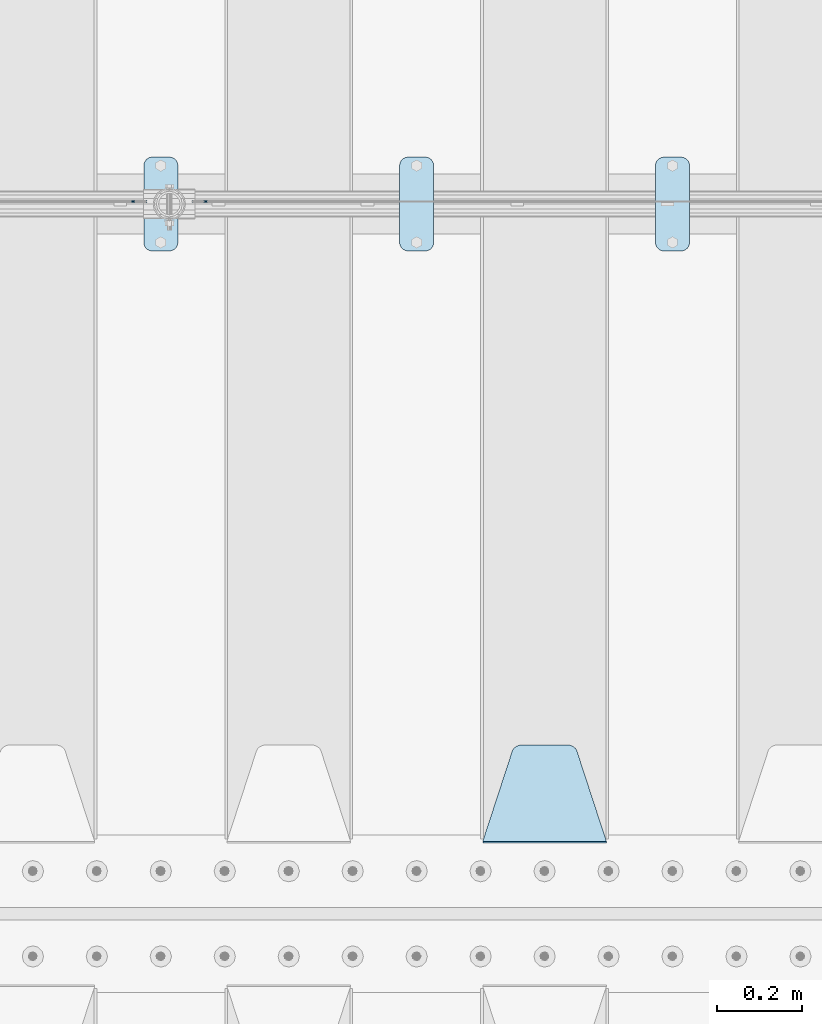
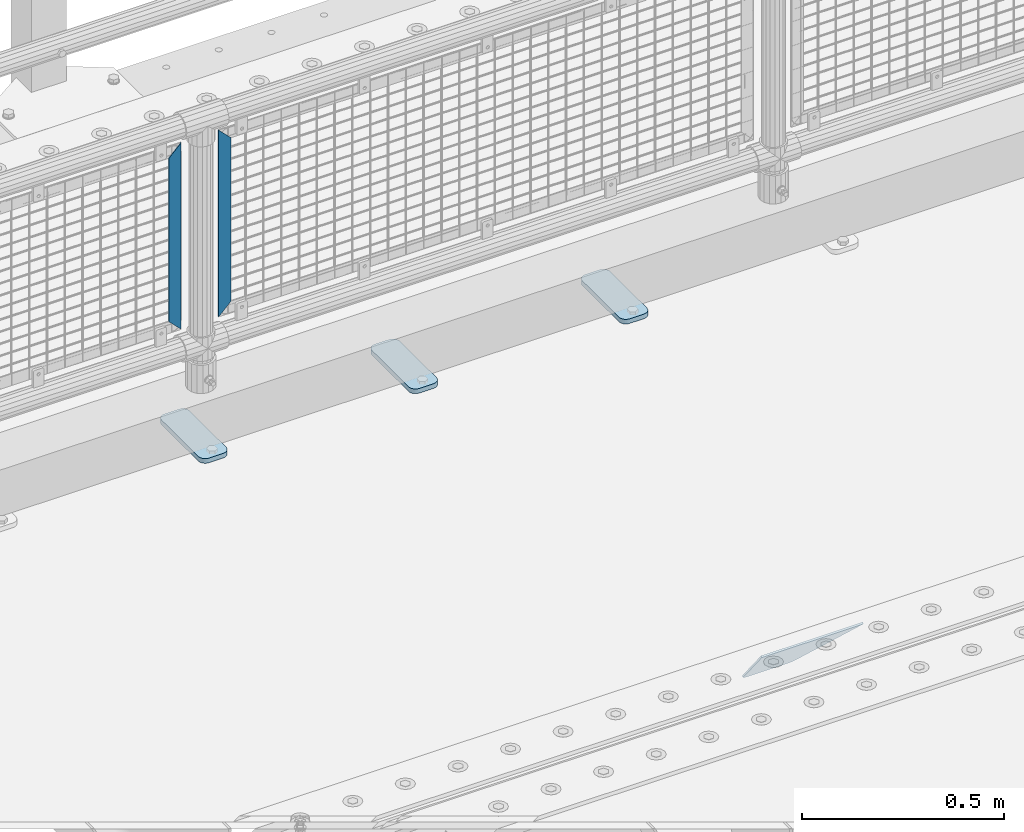
# One storey, part 203 of 242: 6 plates.
"""IFC2X3 building model written with IfcOpenShell, lengths in millimetres."""

from ifc_helpers import new_model, si_unit, frame, origin_with_axes, place, context, subcontext, project, spatial, faceted_brep, material, type_object, element, save


model = new_model("IFC2X3")

# Units and contexts
model_context = context("Model", 3, precision=1e-05, world=origin_with_axes())
body_context = subcontext(model_context, "Body", "Model", "MODEL_VIEW")
ifc_project = project(units=[si_unit("LENGTHUNIT", "METRE", prefix="MILLI"), si_unit("AREAUNIT", "SQUARE_METRE"), si_unit("VOLUMEUNIT", "CUBIC_METRE"), si_unit("MASSUNIT", "GRAM", prefix="KILO"), si_unit("TIMEUNIT", "SECOND"), si_unit("PLANEANGLEUNIT", "RADIAN"), si_unit("SOLIDANGLEUNIT", "STERADIAN"), si_unit("THERMODYNAMICTEMPERATUREUNIT", "DEGREE_CELSIUS"), si_unit("LUMINOUSINTENSITYUNIT", "LUMEN")], contexts=[model_context])

# Site, building, storey
site_placement = place(None, origin_with_axes())
site = spatial("IfcSite", under=ifc_project, at=site_placement, CompositionType="ELEMENT")
building_placement = place(site_placement, origin_with_axes())
building = spatial("IfcBuilding", under=site, at=building_placement, Name="Standard", CompositionType="ELEMENT")
storey_placement = place(building_placement, origin_with_axes())
storey = spatial("IfcBuildingStorey", under=building, at=storey_placement, Name="Undefined", CompositionType="ELEMENT", Elevation=0.0)

# Plates
ifc_material_1 = material(Name="Misc_Undefined")
plate_type_1 = type_object("IfcPlateType", PredefinedType="NOTDEFINED")
plate_1_placement = place(storey_placement, frame((-36841.490286459, -19329.5, 879.519963133601), z_axis=(-0.707008801899319, 0.0, -0.707204746899291), x_axis=(-0.707204746899296, 0.0, 0.707008801899313)))
element("IfcPlate", 1, at=plate_1_placement, inside=storey, type_object=plate_type_1, material=ifc_material_1, context=body_context, shape_type="Brep", body=[
    faceted_brep([(0.0, -1.50000000000364, 0.0), (-348.552185058597, -1.5, 348.655029296875), (-348.552185058597, 1.5, 348.655029296875), (-3.63797880709171e-12, 1.49999999999636, 0.0), (-348.544891357426, -1.5, 398.152496337891), (-348.544891357426, 1.5, 398.152496337891), (49.5043945312464, -1.5, 8.00355337560177e-11), (49.5043945312464, 1.5, 8.00355337560177e-11)], [[[0, 1, 2, 3]], [[1, 4, 5, 2]], [[4, 6, 7, 5]], [[6, 0, 3, 7]], [[5, 7, 3, 2]], [[6, 4, 1, 0]]]),
])
plate_2_placement = place(storey_placement, frame((-37018.5003125164, -19329.5, 879.52), z_axis=(0.707103624179499, 0.0, -0.707109938179501), x_axis=(0.707109938179508, 0.0, 0.707103624179492)))
element("IfcPlate", 2, at=plate_2_placement, inside=storey, type_object=plate_type_1, material=ifc_material_1, context=body_context, shape_type="Brep", body=[
    faceted_brep([(0.0, -1.50000000000364, 0.0), (-348.605163574222, -1.5, 348.602081298832), (-348.605163574222, 1.5, 348.602081298832), (-3.63797880709171e-12, 1.49999999999636, 0.0), (-348.605163574222, -1.5, 398.099334716801), (-348.605163574222, 1.5, 398.099334716801), (49.4976959228534, -1.5, -3.63797880709171e-12), (49.4976959228534, 1.5, -3.63797880709171e-12)], [[[0, 1, 2, 3]], [[1, 4, 5, 2]], [[4, 6, 7, 5]], [[6, 0, 3, 7]], [[5, 7, 3, 2]], [[6, 4, 1, 0]]]),
])
ifc_material_2 = material(Name="STEEL/S355J2")
plate_type_2 = type_object("IfcPlateType", PredefinedType="NOTDEFINED")
plate_3_placement = place(storey_placement, frame((-35790.0, -19225.5, 21.0199999999977), z_axis=(1.0, 0.0, 0.0), x_axis=(0.0, -1.0, 0.0)))
element("IfcPlate", 3, at=plate_3_placement, inside=storey, type_object=plate_type_2, material=ifc_material_2, context=body_context, shape_type="Brep", body=[
    faceted_brep([(0.0, -7.0, 20.0), (0.0, -7.0, 60.0), (0.0, 7.0, 60.0), (0.0, 7.0, 20.0), (0.384294391937146, -7.0, 63.9018064403208), (0.384294391937146, 7.0, 63.9018064403208), (1.52240934977453, -7.0, 67.6536686473009), (1.52240934977453, 7.0, 67.6536686473009), (3.37060775395003, -7.0, 71.1114046603907), (3.37060775395003, 7.0, 71.1114046603907), (5.8578643762703, -7.0, 74.1421356237297), (5.8578643762703, 7.0, 74.1421356237297), (8.88859533960931, -7.0, 76.62939224605), (8.88859533960931, 7.0, 76.62939224605), (12.3463313526991, -7.0, 78.4775906502255), (12.3463313526991, 7.0, 78.4775906502255), (16.0981935596792, -7.0, 79.6157056080629), (16.0981935596792, 7.0, 79.6157056080629), (20.0, -7.0, 80.0), (20.0, 7.0, 80.0), (200.0, -7.0, 80.0), (200.0, 7.0, 80.0), (203.901806440321, -7.0, 79.6157056080629), (203.901806440321, 7.0, 79.6157056080629), (207.653668647301, -7.0, 78.4775906502255), (207.653668647301, 7.0, 78.4775906502255), (211.111404660391, -7.0, 76.62939224605), (211.111404660391, 7.0, 76.62939224605), (214.14213562373, -7.0, 74.1421356237297), (214.14213562373, 7.0, 74.1421356237297), (216.62939224605, -7.0, 71.1114046603907), (216.62939224605, 7.0, 71.1114046603907), (218.477590650225, -7.0, 67.6536686473009), (218.477590650225, 7.0, 67.6536686473009), (219.615705608063, -7.0, 63.9018064403208), (219.615705608063, 7.0, 63.9018064403208), (220.0, -7.0, 60.0), (220.0, 7.0, 60.0), (220.0, -7.0, 20.0), (220.0, 7.0, 20.0), (219.615705608063, -7.0, 16.0981935596792), (219.615705608063, 7.0, 16.0981935596792), (218.477590650225, -7.0, 12.3463313526991), (218.477590650225, 7.0, 12.3463313526991), (216.62939224605, -7.0, 8.88859533960931), (216.62939224605, 7.0, 8.88859533960931), (214.14213562373, -7.0, 5.8578643762703), (214.14213562373, 7.0, 5.8578643762703), (211.111404660391, -7.0, 3.37060775395003), (211.111404660391, 7.0, 3.37060775395003), (207.653668647301, -7.0, 1.52240934977453), (207.653668647301, 7.0, 1.52240934977453), (203.901806440321, -7.0, 0.384294391937146), (203.901806440321, 7.0, 0.384294391937146), (200.0, -7.0, 0.0), (200.0, 7.0, 0.0), (20.0, -7.0, 0.0), (20.0, 7.0, 0.0), (16.0981935596792, -7.0, 0.384294391937146), (16.0981935596792, 7.0, 0.384294391937146), (12.3463313526991, -7.0, 1.52240934977453), (12.3463313526991, 7.0, 1.52240934977453), (8.88859533960931, -7.0, 3.37060775395003), (8.88859533960931, 7.0, 3.37060775395003), (5.8578643762703, -7.0, 5.8578643762703), (5.8578643762703, 7.0, 5.8578643762703), (3.37060775395003, -7.0, 8.88859533960931), (3.37060775395003, 7.0, 8.88859533960931), (1.52240934977453, -7.0, 12.3463313526991), (1.52240934977453, 7.0, 12.3463313526991), (0.384294391937146, -7.0, 16.0981935596792), (0.384294391937146, 7.0, 16.0981935596792)], [[[0, 1, 2, 3]], [[1, 4, 5, 2]], [[4, 6, 7, 5]], [[6, 8, 9, 7]], [[8, 10, 11, 9]], [[10, 12, 13, 11]], [[12, 14, 15, 13]], [[14, 16, 17, 15]], [[16, 18, 19, 17]], [[18, 20, 21, 19]], [[20, 22, 23, 21]], [[22, 24, 25, 23]], [[24, 26, 27, 25]], [[26, 28, 29, 27]], [[28, 30, 31, 29]], [[30, 32, 33, 31]], [[32, 34, 35, 33]], [[34, 36, 37, 35]], [[36, 38, 39, 37]], [[38, 40, 41, 39]], [[40, 42, 43, 41]], [[42, 44, 45, 43]], [[44, 46, 47, 45]], [[46, 48, 49, 47]], [[48, 50, 51, 49]], [[50, 52, 53, 51]], [[52, 54, 55, 53]], [[54, 56, 57, 55]], [[56, 58, 59, 57]], [[58, 60, 61, 59]], [[60, 62, 63, 61]], [[62, 64, 65, 63]], [[64, 66, 67, 65]], [[66, 68, 69, 67]], [[68, 70, 71, 69]], [[70, 0, 3, 71]], [[5, 7, 9, 11, 13, 15, 17, 19, 21, 23, 25, 27, 29, 31, 33, 35, 37, 39, 41, 43, 45, 47, 49, 51, 53, 55, 57, 59, 61, 63, 65, 67, 69, 71, 3, 2]], [[70, 68, 66, 64, 62, 60, 58, 56, 54, 52, 50, 48, 46, 44, 42, 40, 38, 36, 34, 32, 30, 28, 26, 24, 22, 20, 18, 16, 14, 12, 10, 8, 6, 4, 1, 0]]]),
])
plate_4_placement = place(storey_placement, frame((-36390.0, -19225.5, 21.0199999999977), z_axis=(1.0, 0.0, 0.0), x_axis=(0.0, -1.0, 0.0)))
element("IfcPlate", 4, at=plate_4_placement, inside=storey, type_object=plate_type_2, material=ifc_material_2, context=body_context, shape_type="Brep", body=[
    faceted_brep([(0.0, -7.0, 20.0), (0.0, -7.0, 60.0), (0.0, 7.0, 60.0), (0.0, 7.0, 20.0), (0.384294391937146, -7.0, 63.9018064403208), (0.384294391937146, 7.0, 63.9018064403208), (1.52240934977453, -7.0, 67.6536686473009), (1.52240934977453, 7.0, 67.6536686473009), (3.37060775395003, -7.0, 71.1114046603907), (3.37060775395003, 7.0, 71.1114046603907), (5.8578643762703, -7.0, 74.1421356237297), (5.8578643762703, 7.0, 74.1421356237297), (8.88859533960931, -7.0, 76.62939224605), (8.88859533960931, 7.0, 76.62939224605), (12.3463313526991, -7.0, 78.4775906502255), (12.3463313526991, 7.0, 78.4775906502255), (16.0981935596792, -7.0, 79.6157056080629), (16.0981935596792, 7.0, 79.6157056080629), (20.0, -7.0, 80.0), (20.0, 7.0, 80.0), (200.0, -7.0, 80.0), (200.0, 7.0, 80.0), (203.901806440321, -7.0, 79.6157056080629), (203.901806440321, 7.0, 79.6157056080629), (207.653668647301, -7.0, 78.4775906502255), (207.653668647301, 7.0, 78.4775906502255), (211.111404660391, -7.0, 76.62939224605), (211.111404660391, 7.0, 76.62939224605), (214.14213562373, -7.0, 74.1421356237297), (214.14213562373, 7.0, 74.1421356237297), (216.62939224605, -7.0, 71.1114046603907), (216.62939224605, 7.0, 71.1114046603907), (218.477590650225, -7.0, 67.6536686473009), (218.477590650225, 7.0, 67.6536686473009), (219.615705608063, -7.0, 63.9018064403208), (219.615705608063, 7.0, 63.9018064403208), (220.0, -7.0, 60.0), (220.0, 7.0, 60.0), (220.0, -7.0, 20.0), (220.0, 7.0, 20.0), (219.615705608063, -7.0, 16.0981935596792), (219.615705608063, 7.0, 16.0981935596792), (218.477590650225, -7.0, 12.3463313526991), (218.477590650225, 7.0, 12.3463313526991), (216.62939224605, -7.0, 8.88859533960931), (216.62939224605, 7.0, 8.88859533960931), (214.14213562373, -7.0, 5.8578643762703), (214.14213562373, 7.0, 5.8578643762703), (211.111404660391, -7.0, 3.37060775395003), (211.111404660391, 7.0, 3.37060775395003), (207.653668647301, -7.0, 1.52240934977453), (207.653668647301, 7.0, 1.52240934977453), (203.901806440321, -7.0, 0.384294391937146), (203.901806440321, 7.0, 0.384294391937146), (200.0, -7.0, 0.0), (200.0, 7.0, 0.0), (20.0, -7.0, 0.0), (20.0, 7.0, 0.0), (16.0981935596792, -7.0, 0.384294391937146), (16.0981935596792, 7.0, 0.384294391937146), (12.3463313526991, -7.0, 1.52240934977453), (12.3463313526991, 7.0, 1.52240934977453), (8.88859533960931, -7.0, 3.37060775395003), (8.88859533960931, 7.0, 3.37060775395003), (5.8578643762703, -7.0, 5.8578643762703), (5.8578643762703, 7.0, 5.8578643762703), (3.37060775395003, -7.0, 8.88859533960931), (3.37060775395003, 7.0, 8.88859533960931), (1.52240934977453, -7.0, 12.3463313526991), (1.52240934977453, 7.0, 12.3463313526991), (0.384294391937146, -7.0, 16.0981935596792), (0.384294391937146, 7.0, 16.0981935596792)], [[[0, 1, 2, 3]], [[1, 4, 5, 2]], [[4, 6, 7, 5]], [[6, 8, 9, 7]], [[8, 10, 11, 9]], [[10, 12, 13, 11]], [[12, 14, 15, 13]], [[14, 16, 17, 15]], [[16, 18, 19, 17]], [[18, 20, 21, 19]], [[20, 22, 23, 21]], [[22, 24, 25, 23]], [[24, 26, 27, 25]], [[26, 28, 29, 27]], [[28, 30, 31, 29]], [[30, 32, 33, 31]], [[32, 34, 35, 33]], [[34, 36, 37, 35]], [[36, 38, 39, 37]], [[38, 40, 41, 39]], [[40, 42, 43, 41]], [[42, 44, 45, 43]], [[44, 46, 47, 45]], [[46, 48, 49, 47]], [[48, 50, 51, 49]], [[50, 52, 53, 51]], [[52, 54, 55, 53]], [[54, 56, 57, 55]], [[56, 58, 59, 57]], [[58, 60, 61, 59]], [[60, 62, 63, 61]], [[62, 64, 65, 63]], [[64, 66, 67, 65]], [[66, 68, 69, 67]], [[68, 70, 71, 69]], [[70, 0, 3, 71]], [[5, 7, 9, 11, 13, 15, 17, 19, 21, 23, 25, 27, 29, 31, 33, 35, 37, 39, 41, 43, 45, 47, 49, 51, 53, 55, 57, 59, 61, 63, 65, 67, 69, 71, 3, 2]], [[70, 68, 66, 64, 62, 60, 58, 56, 54, 52, 50, 48, 46, 44, 42, 40, 38, 36, 34, 32, 30, 28, 26, 24, 22, 20, 18, 16, 14, 12, 10, 8, 6, 4, 1, 0]]]),
])
plate_5_placement = place(storey_placement, frame((-36990.0, -19225.5, 21.0199999999977), z_axis=(1.0, 0.0, 0.0), x_axis=(0.0, -1.0, 0.0)))
element("IfcPlate", 5, at=plate_5_placement, inside=storey, type_object=plate_type_2, material=ifc_material_2, context=body_context, shape_type="Brep", body=[
    faceted_brep([(0.0, -7.0, 20.0), (0.0, -7.0, 60.0), (0.0, 7.0, 60.0), (0.0, 7.0, 20.0), (0.384294391937146, -7.0, 63.9018064403208), (0.384294391937146, 7.0, 63.9018064403208), (1.52240934977453, -7.0, 67.6536686473009), (1.52240934977453, 7.0, 67.6536686473009), (3.37060775395003, -7.0, 71.1114046603907), (3.37060775395003, 7.0, 71.1114046603907), (5.8578643762703, -7.0, 74.1421356237297), (5.8578643762703, 7.0, 74.1421356237297), (8.88859533960931, -7.0, 76.62939224605), (8.88859533960931, 7.0, 76.62939224605), (12.3463313526991, -7.0, 78.4775906502255), (12.3463313526991, 7.0, 78.4775906502255), (16.0981935596792, -7.0, 79.6157056080629), (16.0981935596792, 7.0, 79.6157056080629), (20.0, -7.0, 80.0), (20.0, 7.0, 80.0), (200.0, -7.0, 80.0), (200.0, 7.0, 80.0), (203.901806440321, -7.0, 79.6157056080629), (203.901806440321, 7.0, 79.6157056080629), (207.653668647301, -7.0, 78.4775906502255), (207.653668647301, 7.0, 78.4775906502255), (211.111404660391, -7.0, 76.62939224605), (211.111404660391, 7.0, 76.62939224605), (214.14213562373, -7.0, 74.1421356237297), (214.14213562373, 7.0, 74.1421356237297), (216.62939224605, -7.0, 71.1114046603907), (216.62939224605, 7.0, 71.1114046603907), (218.477590650225, -7.0, 67.6536686473009), (218.477590650225, 7.0, 67.6536686473009), (219.615705608063, -7.0, 63.9018064403208), (219.615705608063, 7.0, 63.9018064403208), (220.0, -7.0, 60.0), (220.0, 7.0, 60.0), (220.0, -7.0, 20.0), (220.0, 7.0, 20.0), (219.615705608063, -7.0, 16.0981935596792), (219.615705608063, 7.0, 16.0981935596792), (218.477590650225, -7.0, 12.3463313526991), (218.477590650225, 7.0, 12.3463313526991), (216.62939224605, -7.0, 8.88859533960931), (216.62939224605, 7.0, 8.88859533960931), (214.14213562373, -7.0, 5.8578643762703), (214.14213562373, 7.0, 5.8578643762703), (211.111404660391, -7.0, 3.37060775395003), (211.111404660391, 7.0, 3.37060775395003), (207.653668647301, -7.0, 1.52240934977453), (207.653668647301, 7.0, 1.52240934977453), (203.901806440321, -7.0, 0.384294391937146), (203.901806440321, 7.0, 0.384294391937146), (200.0, -7.0, 0.0), (200.0, 7.0, 0.0), (20.0, -7.0, 0.0), (20.0, 7.0, 0.0), (16.0981935596792, -7.0, 0.384294391937146), (16.0981935596792, 7.0, 0.384294391937146), (12.3463313526991, -7.0, 1.52240934977453), (12.3463313526991, 7.0, 1.52240934977453), (8.88859533960931, -7.0, 3.37060775395003), (8.88859533960931, 7.0, 3.37060775395003), (5.8578643762703, -7.0, 5.8578643762703), (5.8578643762703, 7.0, 5.8578643762703), (3.37060775395003, -7.0, 8.88859533960931), (3.37060775395003, 7.0, 8.88859533960931), (1.52240934977453, -7.0, 12.3463313526991), (1.52240934977453, 7.0, 12.3463313526991), (0.384294391937146, -7.0, 16.0981935596792), (0.384294391937146, 7.0, 16.0981935596792)], [[[0, 1, 2, 3]], [[1, 4, 5, 2]], [[4, 6, 7, 5]], [[6, 8, 9, 7]], [[8, 10, 11, 9]], [[10, 12, 13, 11]], [[12, 14, 15, 13]], [[14, 16, 17, 15]], [[16, 18, 19, 17]], [[18, 20, 21, 19]], [[20, 22, 23, 21]], [[22, 24, 25, 23]], [[24, 26, 27, 25]], [[26, 28, 29, 27]], [[28, 30, 31, 29]], [[30, 32, 33, 31]], [[32, 34, 35, 33]], [[34, 36, 37, 35]], [[36, 38, 39, 37]], [[38, 40, 41, 39]], [[40, 42, 43, 41]], [[42, 44, 45, 43]], [[44, 46, 47, 45]], [[46, 48, 49, 47]], [[48, 50, 51, 49]], [[50, 52, 53, 51]], [[52, 54, 55, 53]], [[54, 56, 57, 55]], [[56, 58, 59, 57]], [[58, 60, 61, 59]], [[60, 62, 63, 61]], [[62, 64, 65, 63]], [[64, 66, 67, 65]], [[66, 68, 69, 67]], [[68, 70, 71, 69]], [[70, 0, 3, 71]], [[5, 7, 9, 11, 13, 15, 17, 19, 21, 23, 25, 27, 29, 31, 33, 35, 37, 39, 41, 43, 45, 47, 49, 51, 53, 55, 57, 59, 61, 63, 65, 67, 69, 71, 3, 2]], [[70, 68, 66, 64, 62, 60, 58, 56, 54, 52, 50, 48, 46, 44, 42, 40, 38, 36, 34, 32, 30, 28, 26, 24, 22, 20, 18, 16, 14, 12, 10, 8, 6, 4, 1, 0]]]),
])
ifc_material_3 = material(Name="STEEL/S355N")
plate_type_3 = type_object("IfcPlateType", PredefinedType="NOTDEFINED")
plate_6_placement = place(storey_placement, frame((-35905.0, -20831.767766953, -1.76776695296758), z_axis=(0.0, 0.707106781186547, -0.707106781186548), x_axis=(-1.0, 0.0, 0.0)))
element("IfcPlate", 6, at=plate_6_placement, inside=storey, type_object=plate_type_3, material=ifc_material_3, context=body_context, shape_type="Brep", body=[
    faceted_brep([(0.0, -2.5, 0.0), (69.345504679477, -2.50000000000182, 300.171731424829), (69.345504679477, 2.5, 300.171731424829), (0.0, 2.5, 0.0), (70.9274061199576, -2.5, 304.897442415398), (70.9274061199576, 2.5, 304.897442415398), (73.3818627772307, -2.5, 309.234538108525), (73.3818627772307, 2.50000000000182, 309.234538108529), (76.6187032999551, -2.5, 313.023683126101), (76.6187032999551, 2.50000000000182, 313.023683126103), (80.5190132704993, -2.5, 316.12567259537), (80.5190132704993, 2.5, 316.12567259537), (84.9395038596849, -2.5, 318.426546230474), (84.9395038596849, 2.50000000000182, 318.426546230476), (89.7177759439219, -2.49999999999818, 319.841774983273), (89.7177759439219, 2.50000000000182, 319.841774983273), (94.678286292652, -2.5, 320.319366455076), (94.678286292652, 2.5, 320.319366455076), (195.321713707348, -2.5, 320.319366455076), (195.321713707348, 2.5, 320.319366455076), (200.282224056078, -2.5, 319.841774983272), (200.282224056078, 2.50000000000182, 319.841774983273), (205.060496140315, -2.5, 318.426546230474), (205.060496140315, 2.49999999999818, 318.426546230474), (209.480986729501, -2.49999999999818, 316.12567259537), (209.480986729501, 2.5, 316.12567259537), (213.381296700045, -2.5, 313.023683126101), (213.381296700045, 2.49999999999818, 313.023683126101), (216.618137222769, -2.5, 309.234538108525), (216.618137222769, 2.5, 309.234538108523), (219.072593880042, -2.49999999999818, 304.897442415398), (219.072593880042, 2.50000000000182, 304.897442415398), (220.654495320523, -2.50000000000182, 300.171731424829), (220.654495320523, 2.5, 300.171731424829), (290.0, -2.5, 0.0), (290.0, 2.5, -1.81898940354586e-12)], [[[0, 1, 2, 3]], [[1, 4, 5, 2]], [[4, 6, 7, 5]], [[6, 8, 9, 7]], [[8, 10, 11, 9]], [[10, 12, 13, 11]], [[12, 14, 15, 13]], [[14, 16, 17, 15]], [[16, 18, 19, 17]], [[18, 20, 21, 19]], [[20, 22, 23, 21]], [[22, 24, 25, 23]], [[24, 26, 27, 25]], [[26, 28, 29, 27]], [[28, 30, 31, 29]], [[30, 32, 33, 31]], [[32, 34, 35, 33]], [[34, 0, 3, 35]], [[5, 7, 9, 11, 13, 15, 17, 19, 21, 23, 25, 27, 29, 31, 33, 35, 3, 2]], [[34, 32, 30, 28, 26, 24, 22, 20, 18, 16, 14, 12, 10, 8, 6, 4, 1, 0]]]),
])

save(model, "model.ifc")
